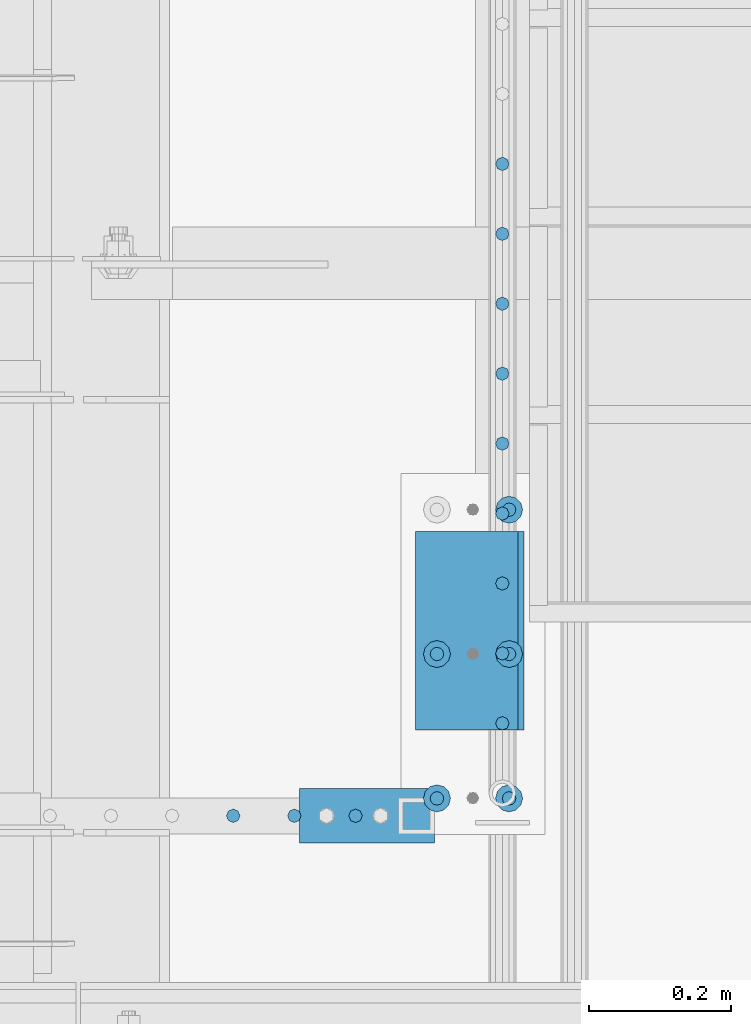
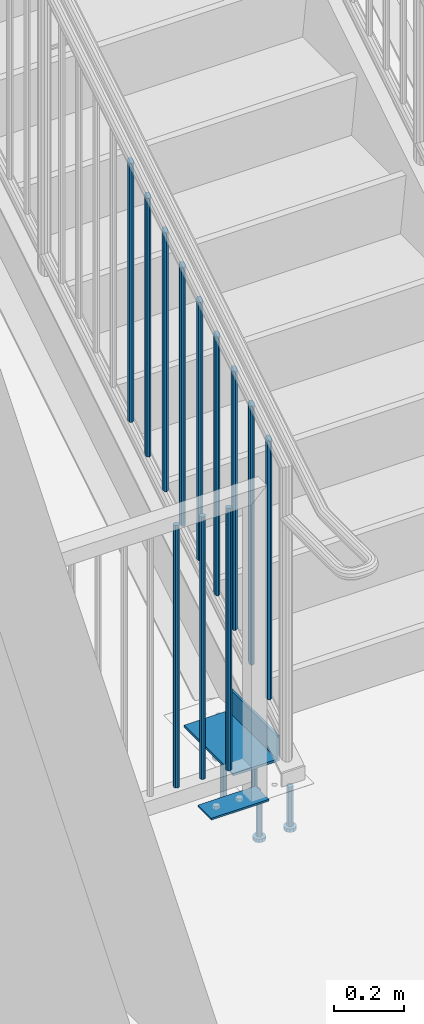
# One storey, part 1259 of 1763: 19 beams, 4 elements without a shape of their own.
"""IFC2X3 building model written with IfcOpenShell, lengths in millimetres."""

from ifc_helpers import new_model, si_unit, frame, origin_with_axes, place, context, subcontext, project, spatial, faceted_brep, material, type_object, element, aggregate, save


model = new_model("IFC2X3")

# Units and contexts
model_context = context("Model", 3, precision=1e-05, world=origin_with_axes())
body_context = subcontext(model_context, "Body", "Model", "MODEL_VIEW")
ifc_project = project(units=[si_unit("LENGTHUNIT", "METRE", prefix="MILLI"), si_unit("AREAUNIT", "SQUARE_METRE"), si_unit("VOLUMEUNIT", "CUBIC_METRE"), si_unit("MASSUNIT", "GRAM", prefix="KILO"), si_unit("TIMEUNIT", "SECOND"), si_unit("PLANEANGLEUNIT", "RADIAN"), si_unit("SOLIDANGLEUNIT", "STERADIAN"), si_unit("THERMODYNAMICTEMPERATUREUNIT", "DEGREE_CELSIUS"), si_unit("LUMINOUSINTENSITYUNIT", "LUMEN")], contexts=[model_context])

# Site, building, storey
site_placement = place(None, origin_with_axes())
site = spatial("IfcSite", under=ifc_project, at=site_placement, CompositionType="ELEMENT")
building_placement = place(site_placement, origin_with_axes())
building = spatial("IfcBuilding", under=site, at=building_placement, Name="Undefined", CompositionType="ELEMENT")
storey_placement = place(building_placement, origin_with_axes())
storey = spatial("IfcBuildingStorey", under=building, at=storey_placement, Name="Undefined", CompositionType="ELEMENT", Elevation=0.0)

# Assembly, beams
assembly_1_placement = place(storey_placement, origin_with_axes())
assembly_1 = element("IfcElementAssembly", 1, at=assembly_1_placement, inside=storey, Name="GUARDRAIL", AssemblyPlace="NOTDEFINED", PredefinedType="RIGID_FRAME")
ifc_material_1 = material(Name="STEEL/A36")
beam_type_1 = type_object("IfcBeamType", PredefinedType="NOTDEFINED")
beam_1_placement = place(assembly_1_placement, frame((-86969.0372737229, 31984.9500064728, 307.975030132566), z_axis=(-1.0, 0.0, 0.0), x_axis=(0.0, 1.0, 0.0)))
beam_1 = element("IfcBeam", 2, at=beam_1_placement, type_object=beam_type_1, material=ifc_material_1, context=body_context, shape_type="Brep", body=[
    faceted_brep([(0.0, 3.17500000000001, -95.25), (0.0, 3.17499999999927, 95.25), (76.1999968561649, 3.17499999984284, 95.25), (76.1999999999971, 3.17500000000001, -95.25), (0.0, -3.17499999999927, 95.25), (76.1999970403122, -3.17500000015571, 95.25), (0.0, -3.17500000000001, -95.25), (76.1999999999971, -3.17500000000001, -95.25)], [[[0, 1, 2, 3]], [[1, 4, 5, 2]], [[4, 6, 7, 5]], [[6, 0, 3, 7]], [[5, 7, 3, 2]], [[6, 4, 1, 0]]]),
])
beam_type_2 = type_object("IfcBeamType", PredefinedType="NOTDEFINED")
beam_2_placement = place(assembly_1_placement, frame((-86985.2650514979, 32023.0500064728, 1346.20003013257), z_axis=(1.0, 0.0, 0.0), x_axis=(0.0, 0.0, -1.0)))
beam_2 = element("IfcBeam", 3, at=beam_2_placement, type_object=beam_type_2, material=ifc_material_1, Name="PICKET", context=body_context, shape_type="Brep", body=[
    faceted_brep([(0.0, -9.52500000000146, 0.0), (0.0, -6.73519209080041, -6.73519209079677), (913.809358181841, -6.73519209080041, -6.73519209079677), (913.809358181841, -9.52500000000146, 0.0), (0.0, 0.0, -9.52499999999418), (913.809358181841, 0.0, -9.52499999999418), (0.0, 6.73519209080041, -6.73519209079677), (913.809358181841, 6.73519209080041, -6.73519209079677), (0.0, 9.52500000000146, 0.0), (913.809358181841, 9.52500000000146, 0.0), (0.0, 6.73519209080041, 6.73519209079677), (913.809358181841, 6.73519209080041, 6.73519209079677), (0.0, 0.0, 9.52499999999418), (913.809358181841, 0.0, 9.52499999999418), (0.0, -6.73519209080041, 6.73519209079677), (913.809358181841, -6.73519209080041, 6.73519209079677)], [[[0, 1, 2, 3]], [[1, 4, 5, 2]], [[4, 6, 7, 5]], [[6, 8, 9, 7]], [[8, 10, 11, 9]], [[10, 12, 13, 11]], [[12, 14, 15, 13]], [[14, 0, 3, 15]], [[5, 7, 9, 11, 13, 15, 3, 2]], [[14, 12, 10, 8, 6, 4, 1, 0]]]),
])
beam_3_placement = place(assembly_1_placement, frame((-87071.342829273, 32023.0500064728, 1346.20003013257), z_axis=(1.0, 0.0, 0.0), x_axis=(0.0, 0.0, -1.0)))
beam_3 = element("IfcBeam", 4, at=beam_3_placement, type_object=beam_type_2, material=ifc_material_1, Name="PICKET", context=body_context, shape_type="Brep", body=[
    faceted_brep([(0.0, -9.52500000000146, 0.0), (0.0, -6.73519209080041, -6.73519209079677), (913.809358181841, -6.73519209080041, -6.73519209079677), (913.809358181841, -9.52500000000146, 0.0), (0.0, 0.0, -9.52499999999418), (913.809358181841, 0.0, -9.52499999999418), (0.0, 6.73519209080041, -6.73519209079677), (913.809358181841, 6.73519209080041, -6.73519209079677), (0.0, 9.52500000000146, 0.0), (913.809358181841, 9.52500000000146, 0.0), (0.0, 6.73519209080041, 6.73519209079677), (913.809358181841, 6.73519209080041, 6.73519209079677), (0.0, 0.0, 9.52499999999418), (913.809358181841, 0.0, 9.52499999999418), (0.0, -6.73519209080041, 6.73519209079677), (913.809358181841, -6.73519209080041, 6.73519209079677)], [[[0, 1, 2, 3]], [[1, 4, 5, 2]], [[4, 6, 7, 5]], [[6, 8, 9, 7]], [[8, 10, 11, 9]], [[10, 12, 13, 11]], [[12, 14, 15, 13]], [[14, 0, 3, 15]], [[5, 7, 9, 11, 13, 15, 3, 2]], [[14, 12, 10, 8, 6, 4, 1, 0]]]),
])
beam_4_placement = place(assembly_1_placement, frame((-87157.420607048, 32023.0500064728, 1346.20003013257), z_axis=(1.0, 0.0, 0.0), x_axis=(0.0, 0.0, -1.0)))
beam_4 = element("IfcBeam", 5, at=beam_4_placement, type_object=beam_type_2, material=ifc_material_1, Name="PICKET", context=body_context, shape_type="Brep", body=[
    faceted_brep([(0.0, -9.52500000000146, 0.0), (0.0, -6.73519209080041, -6.73519209079677), (913.809358181841, -6.73519209080041, -6.73519209079677), (913.809358181841, -9.52500000000146, 0.0), (0.0, 0.0, -9.52499999999418), (913.809358181841, 0.0, -9.52499999999418), (0.0, 6.73519209080041, -6.73519209079677), (913.809358181841, 6.73519209080041, -6.73519209079677), (0.0, 9.52500000000146, 0.0), (913.809358181841, 9.52500000000146, 0.0), (0.0, 6.73519209080041, 6.73519209079677), (913.809358181841, 6.73519209080041, 6.73519209079677), (0.0, 0.0, 9.52499999999418), (913.809358181841, 0.0, 9.52499999999418), (0.0, -6.73519209080041, 6.73519209079677), (913.809358181841, -6.73519209080041, 6.73519209079677)], [[[0, 1, 2, 3]], [[1, 4, 5, 2]], [[4, 6, 7, 5]], [[6, 8, 9, 7]], [[8, 10, 11, 9]], [[10, 12, 13, 11]], [[12, 14, 15, 13]], [[14, 0, 3, 15]], [[5, 7, 9, 11, 13, 15, 3, 2]], [[14, 12, 10, 8, 6, 4, 1, 0]]]),
])
aggregate(assembly_1, [beam_1, beam_2, beam_3, beam_4])

assembly_2_placement = place(storey_placement, origin_with_axes())
assembly_2 = element("IfcElementAssembly", 6, at=assembly_2_placement, inside=storey, Name="RAIL", AssemblyPlace="NOTDEFINED", PredefinedType="RIGID_FRAME")
beam_5_placement = place(assembly_2_placement, frame((-86778.5372736927, 32940.8971432264, 1945.09755526752), z_axis=(-1.0, 0.0, 0.0), x_axis=(0.0, 0.0, -1.0)))
beam_5 = element("IfcBeam", 7, at=beam_5_placement, type_object=beam_type_2, material=ifc_material_1, Name="PICKET", context=body_context, shape_type="Brep", body=[
    faceted_brep([(16.5091072770651, -9.52500000000146, 0.0), (18.2402825153672, -6.73519209080405, -6.73519209079677), (919.550864034841, -6.73519209080405, -6.73519209079677), (917.819688796539, -9.52500000000146, 0.0), (22.4197092545201, 0.0, -9.52499999999418), (923.730290773995, 0.0, -9.52499999999418), (26.5991359936734, 6.73519209080405, -6.73519209079677), (927.909717513148, 6.73519209080405, -6.73519209079677), (28.330311231975, 9.52500000000146, 0.0), (929.64089275145, 9.52500000000146, 0.0), (26.5991359936734, 6.73519209080405, 6.73519209079677), (927.909717513148, 6.73519209080405, 6.73519209079677), (22.4197092545201, 0.0, 9.52499999999418), (923.730290773995, 0.0, 9.52499999999418), (18.2402825153672, -6.73519209080405, 6.73519209079677), (919.550864034841, -6.73519209080405, 6.73519209079677)], [[[0, 1, 2, 3]], [[1, 4, 5, 2]], [[4, 6, 7, 5]], [[6, 8, 9, 7]], [[8, 10, 11, 9]], [[10, 12, 13, 11]], [[12, 14, 15, 13]], [[14, 0, 3, 15]], [[13, 15, 3, 2, 5, 7, 9, 11]], [[14, 12, 10, 8, 6, 4, 1, 0]]]),
])
beam_6_placement = place(assembly_2_placement, frame((-86778.5372736927, 32842.4419051312, 1884.00257101841), z_axis=(-1.0, 0.0, 0.0), x_axis=(0.0, 0.0, -1.0)))
beam_6 = element("IfcBeam", 8, at=beam_6_placement, type_object=beam_type_2, material=ifc_material_1, Name="PICKET", context=body_context, shape_type="Brep", body=[
    faceted_brep([(16.5091072770651, -9.52500000000146, 0.0), (18.2402825153672, -6.73519209080405, -6.73519209079677), (919.550864034841, -6.73519209080405, -6.73519209079677), (917.819688796539, -9.52500000000146, 0.0), (22.4197092545201, 0.0, -9.52499999999418), (923.730290773995, 0.0, -9.52499999999418), (26.5991359936734, 6.73519209080405, -6.73519209079677), (927.909717513148, 6.73519209080405, -6.73519209079677), (28.330311231975, 9.52500000000146, 0.0), (929.64089275145, 9.52500000000146, 0.0), (26.5991359936734, 6.73519209080405, 6.73519209079677), (927.909717513148, 6.73519209080405, 6.73519209079677), (22.4197092545201, 0.0, 9.52499999999418), (923.730290773995, 0.0, 9.52499999999418), (18.2402825153672, -6.73519209080405, 6.73519209079677), (919.550864034841, -6.73519209080405, 6.73519209079677)], [[[0, 1, 2, 3]], [[1, 4, 5, 2]], [[4, 6, 7, 5]], [[6, 8, 9, 7]], [[8, 10, 11, 9]], [[10, 12, 13, 11]], [[12, 14, 15, 13]], [[14, 0, 3, 15]], [[13, 15, 3, 2, 5, 7, 9, 11]], [[14, 12, 10, 8, 6, 4, 1, 0]]]),
])
beam_7_placement = place(assembly_2_placement, frame((-86778.5372736927, 32743.986667036, 1822.90758676929), z_axis=(-1.0, 0.0, 0.0), x_axis=(0.0, 0.0, -1.0)))
beam_7 = element("IfcBeam", 9, at=beam_7_placement, type_object=beam_type_2, material=ifc_material_1, Name="PICKET", context=body_context, shape_type="Brep", body=[
    faceted_brep([(16.5091072770651, -9.52500000000146, 0.0), (18.2402825153672, -6.73519209080405, -6.73519209079677), (919.550864034841, -6.73519209080405, -6.73519209079677), (917.819688796539, -9.52500000000146, 0.0), (22.4197092545201, 0.0, -9.52499999999418), (923.730290773995, 0.0, -9.52499999999418), (26.5991359936734, 6.73519209080405, -6.73519209079677), (927.909717513148, 6.73519209080405, -6.73519209079677), (28.330311231975, 9.52500000000146, 0.0), (929.64089275145, 9.52500000000146, 0.0), (26.5991359936734, 6.73519209080405, 6.73519209079677), (927.909717513148, 6.73519209080405, 6.73519209079677), (22.4197092545201, 0.0, 9.52499999999418), (923.730290773995, 0.0, 9.52499999999418), (18.2402825153672, -6.73519209080405, 6.73519209079677), (919.550864034841, -6.73519209080405, 6.73519209079677)], [[[0, 1, 2, 3]], [[1, 4, 5, 2]], [[4, 6, 7, 5]], [[6, 8, 9, 7]], [[8, 10, 11, 9]], [[10, 12, 13, 11]], [[12, 14, 15, 13]], [[14, 0, 3, 15]], [[13, 15, 3, 2, 5, 7, 9, 11]], [[14, 12, 10, 8, 6, 4, 1, 0]]]),
])
beam_8_placement = place(assembly_2_placement, frame((-86778.5372736927, 32645.5314289407, 1761.81260252017), z_axis=(-1.0, 0.0, 0.0), x_axis=(0.0, 0.0, -1.0)))
beam_8 = element("IfcBeam", 10, at=beam_8_placement, type_object=beam_type_2, material=ifc_material_1, Name="PICKET", context=body_context, shape_type="Brep", body=[
    faceted_brep([(16.5091072770651, -9.52500000000146, 0.0), (18.2402825153672, -6.73519209080405, -6.73519209079677), (919.550864034841, -6.73519209080405, -6.73519209079677), (917.819688796539, -9.52500000000146, 0.0), (22.4197092545201, 0.0, -9.52499999999418), (923.730290773995, 0.0, -9.52499999999418), (26.5991359936734, 6.73519209080405, -6.73519209079677), (927.909717513148, 6.73519209080405, -6.73519209079677), (28.330311231975, 9.52500000000146, 0.0), (929.64089275145, 9.52500000000146, 0.0), (26.5991359936734, 6.73519209080405, 6.73519209079677), (927.909717513148, 6.73519209080405, 6.73519209079677), (22.4197092545201, 0.0, 9.52499999999418), (923.730290773995, 0.0, 9.52499999999418), (18.2402825153672, -6.73519209080405, 6.73519209079677), (919.550864034841, -6.73519209080405, 6.73519209079677)], [[[0, 1, 2, 3]], [[1, 4, 5, 2]], [[4, 6, 7, 5]], [[6, 8, 9, 7]], [[8, 10, 11, 9]], [[10, 12, 13, 11]], [[12, 14, 15, 13]], [[14, 0, 3, 15]], [[13, 15, 3, 2, 5, 7, 9, 11]], [[14, 12, 10, 8, 6, 4, 1, 0]]]),
])
beam_9_placement = place(assembly_2_placement, frame((-86778.5372736927, 32547.0761908455, 1700.71761827105), z_axis=(-1.0, 0.0, 0.0), x_axis=(0.0, 0.0, -1.0)))
beam_9 = element("IfcBeam", 11, at=beam_9_placement, type_object=beam_type_2, material=ifc_material_1, Name="PICKET", context=body_context, shape_type="Brep", body=[
    faceted_brep([(16.5091072770651, -9.52500000000146, 0.0), (18.2402825153672, -6.73519209080405, -6.73519209079677), (919.550864034841, -6.73519209080405, -6.73519209079677), (917.819688796539, -9.52500000000146, 0.0), (22.4197092545201, 0.0, -9.52499999999418), (923.730290773995, 0.0, -9.52499999999418), (26.5991359936734, 6.73519209080405, -6.73519209079677), (927.909717513148, 6.73519209080405, -6.73519209079677), (28.330311231975, 9.52500000000146, 0.0), (929.64089275145, 9.52500000000146, 0.0), (26.5991359936734, 6.73519209080405, 6.73519209079677), (927.909717513148, 6.73519209080405, 6.73519209079677), (22.4197092545201, 0.0, 9.52499999999418), (923.730290773995, 0.0, 9.52499999999418), (18.2402825153672, -6.73519209080405, 6.73519209079677), (919.550864034841, -6.73519209080405, 6.73519209079677)], [[[0, 1, 2, 3]], [[1, 4, 5, 2]], [[4, 6, 7, 5]], [[6, 8, 9, 7]], [[8, 10, 11, 9]], [[10, 12, 13, 11]], [[12, 14, 15, 13]], [[14, 0, 3, 15]], [[13, 15, 3, 2, 5, 7, 9, 11]], [[14, 12, 10, 8, 6, 4, 1, 0]]]),
])
beam_10_placement = place(assembly_2_placement, frame((-86778.5372736927, 32448.6209527502, 1639.62263402193), z_axis=(-1.0, 0.0, 0.0), x_axis=(0.0, 0.0, -1.0)))
beam_10 = element("IfcBeam", 12, at=beam_10_placement, type_object=beam_type_2, material=ifc_material_1, Name="PICKET", context=body_context, shape_type="Brep", body=[
    faceted_brep([(16.5091072770651, -9.52500000000146, 0.0), (18.2402825153672, -6.73519209080405, -6.73519209079677), (919.550864034841, -6.73519209080405, -6.73519209079677), (917.819688796539, -9.52500000000146, 0.0), (22.4197092545201, 0.0, -9.52499999999418), (923.730290773995, 0.0, -9.52499999999418), (26.5991359936734, 6.73519209080405, -6.73519209079677), (927.909717513148, 6.73519209080405, -6.73519209079677), (28.330311231975, 9.52500000000146, 0.0), (929.64089275145, 9.52500000000146, 0.0), (26.5991359936734, 6.73519209080405, 6.73519209079677), (927.909717513148, 6.73519209080405, 6.73519209079677), (22.4197092545201, 0.0, 9.52499999999418), (923.730290773995, 0.0, 9.52499999999418), (18.2402825153672, -6.73519209080405, 6.73519209079677), (919.550864034841, -6.73519209080405, 6.73519209079677)], [[[0, 1, 2, 3]], [[1, 4, 5, 2]], [[4, 6, 7, 5]], [[6, 8, 9, 7]], [[8, 10, 11, 9]], [[10, 12, 13, 11]], [[12, 14, 15, 13]], [[14, 0, 3, 15]], [[13, 15, 3, 2, 5, 7, 9, 11]], [[14, 12, 10, 8, 6, 4, 1, 0]]]),
])
beam_11_placement = place(assembly_2_placement, frame((-86778.5372736927, 32350.165714655, 1578.52764977282), z_axis=(-1.0, 0.0, 0.0), x_axis=(0.0, 0.0, -1.0)))
beam_11 = element("IfcBeam", 13, at=beam_11_placement, type_object=beam_type_2, material=ifc_material_1, Name="PICKET", context=body_context, shape_type="Brep", body=[
    faceted_brep([(16.5091072770651, -9.52500000000146, 0.0), (18.2402825153672, -6.73519209080405, -6.73519209079677), (919.550864034841, -6.73519209080405, -6.73519209079677), (917.819688796539, -9.52500000000146, 0.0), (22.4197092545201, 0.0, -9.52499999999418), (923.730290773995, 0.0, -9.52499999999418), (26.5991359936734, 6.73519209080405, -6.73519209079677), (927.909717513148, 6.73519209080405, -6.73519209079677), (28.330311231975, 9.52500000000146, 0.0), (929.64089275145, 9.52500000000146, 0.0), (26.5991359936734, 6.73519209080405, 6.73519209079677), (927.909717513148, 6.73519209080405, 6.73519209079677), (22.4197092545201, 0.0, 9.52499999999418), (923.730290773995, 0.0, 9.52499999999418), (18.2402825153672, -6.73519209080405, 6.73519209079677), (919.550864034841, -6.73519209080405, 6.73519209079677)], [[[0, 1, 2, 3]], [[1, 4, 5, 2]], [[4, 6, 7, 5]], [[6, 8, 9, 7]], [[8, 10, 11, 9]], [[10, 12, 13, 11]], [[12, 14, 15, 13]], [[14, 0, 3, 15]], [[13, 15, 3, 2, 5, 7, 9, 11]], [[14, 12, 10, 8, 6, 4, 1, 0]]]),
])
beam_12_placement = place(assembly_2_placement, frame((-86778.5372736927, 32251.7104765598, 1517.4326655237), z_axis=(-1.0, 0.0, 0.0), x_axis=(0.0, 0.0, -1.0)))
beam_12 = element("IfcBeam", 14, at=beam_12_placement, type_object=beam_type_2, material=ifc_material_1, Name="PICKET", context=body_context, shape_type="Brep", body=[
    faceted_brep([(16.5091072770651, -9.52500000000146, 0.0), (18.2402825153672, -6.73519209080405, -6.73519209079677), (919.550864034841, -6.73519209080405, -6.73519209079677), (917.819688796539, -9.52500000000146, 0.0), (22.4197092545201, 0.0, -9.52499999999418), (923.730290773995, 0.0, -9.52499999999418), (26.5991359936734, 6.73519209080405, -6.73519209079677), (927.909717513148, 6.73519209080405, -6.73519209079677), (28.330311231975, 9.52500000000146, 0.0), (929.64089275145, 9.52500000000146, 0.0), (26.5991359936734, 6.73519209080405, 6.73519209079677), (927.909717513148, 6.73519209080405, 6.73519209079677), (22.4197092545201, 0.0, 9.52499999999418), (923.730290773995, 0.0, 9.52499999999418), (18.2402825153672, -6.73519209080405, 6.73519209079677), (919.550864034841, -6.73519209080405, 6.73519209079677)], [[[0, 1, 2, 3]], [[1, 4, 5, 2]], [[4, 6, 7, 5]], [[6, 8, 9, 7]], [[8, 10, 11, 9]], [[10, 12, 13, 11]], [[12, 14, 15, 13]], [[14, 0, 3, 15]], [[13, 15, 3, 2, 5, 7, 9, 11]], [[14, 12, 10, 8, 6, 4, 1, 0]]]),
])
beam_13_placement = place(assembly_2_placement, frame((-86778.5372736927, 32153.2552384645, 1456.33768127458), z_axis=(-1.0, 0.0, 0.0), x_axis=(0.0, 0.0, -1.0)))
beam_13 = element("IfcBeam", 15, at=beam_13_placement, type_object=beam_type_2, material=ifc_material_1, Name="PICKET", context=body_context, shape_type="Brep", body=[
    faceted_brep([(16.5091072770651, -9.52500000000146, 0.0), (18.2402825153672, -6.73519209080405, -6.73519209079677), (919.550864034841, -6.73519209080405, -6.73519209079677), (917.819688796539, -9.52500000000146, 0.0), (22.4197092545201, 0.0, -9.52499999999418), (923.730290773995, 0.0, -9.52499999999418), (26.5991359936734, 6.73519209080405, -6.73519209079677), (927.909717513148, 6.73519209080405, -6.73519209079677), (28.330311231975, 9.52500000000146, 0.0), (929.64089275145, 9.52500000000146, 0.0), (26.5991359936734, 6.73519209080405, 6.73519209079677), (927.909717513148, 6.73519209080405, 6.73519209079677), (22.4197092545201, 0.0, 9.52499999999418), (923.730290773995, 0.0, 9.52499999999418), (18.2402825153672, -6.73519209080405, 6.73519209079677), (919.550864034841, -6.73519209080405, 6.73519209079677)], [[[0, 1, 2, 3]], [[1, 4, 5, 2]], [[4, 6, 7, 5]], [[6, 8, 9, 7]], [[8, 10, 11, 9]], [[10, 12, 13, 11]], [[12, 14, 15, 13]], [[14, 0, 3, 15]], [[13, 15, 3, 2, 5, 7, 9, 11]], [[14, 12, 10, 8, 6, 4, 1, 0]]]),
])
aggregate(assembly_2, [beam_5, beam_6, beam_7, beam_8, beam_9, beam_10, beam_11, beam_12, beam_13])

# Assembly, beam
assembly_3_placement = place(storey_placement, origin_with_axes())
assembly_3 = element("IfcElementAssembly", 16, at=assembly_3_placement, inside=storey, Name="STRINGER", AssemblyPlace="NOTDEFINED", PredefinedType="RIGID_FRAME")
beam_type_3 = type_object("IfcBeamType", Name="L6X3-1/2X5/16", PredefinedType="NOTDEFINED")
beam_14_placement = place(assembly_3_placement, frame((-86824.5747737229, 32143.7000003621, 349.249782502056), z_axis=(-1.0, 0.0, 0.0), x_axis=(0.0, 1.0, 0.0)))
beam_14 = element("IfcBeam", 17, at=beam_14_placement, type_object=beam_type_3, material=ifc_material_1, Name="ANGLE", ObjectType="L6X3-1/2X5/16", context=body_context, shape_type="Brep", body=[
    faceted_brep([(0.0, 44.45, -76.1999999999971), (0.0, 44.45, 76.1999999999971), (279.400000000001, 44.45, 76.1999999999971), (279.400000000001, 44.45, -76.1999999999971), (0.0, 36.5125, 76.1999999999971), (279.400000000001, 36.5125, 76.1999999999971), (0.0, 36.5125, -68.2624999999971), (279.400000000001, 36.5125, -68.2624999999971), (0.0, -44.45, -68.2624999999971), (279.400000000001, -44.45, -68.2624999999971), (0.0, -44.45, -76.1999999999971), (279.400000000001, -44.45, -76.1999999999971)], [[[0, 1, 2, 3]], [[1, 4, 5, 2]], [[4, 6, 7, 5]], [[6, 8, 9, 7]], [[8, 10, 11, 9]], [[10, 0, 3, 11]], [[5, 7, 9, 11, 3, 2]], [[10, 8, 6, 4, 1, 0]]]),
])
aggregate(assembly_3, [beam_14])

# Assembly, beams
assembly_4_placement = place(storey_placement, origin_with_axes())
assembly_4 = element("IfcElementAssembly", 18, at=assembly_4_placement, inside=storey, Name="PLATE", AssemblyPlace="NOTDEFINED", PredefinedType="RIGID_FRAME")
ifc_material_2 = material(Name="STEEL/A108")
beam_type_4 = type_object("IfcBeamType", Name="STUD_3/4-DIA", PredefinedType="NOTDEFINED")
beam_15_placement = place(assembly_4_placement, frame((-86769.0122706704, 32047.5777095314, 285.750030132579), z_axis=(1.0, 0.0, 0.0), x_axis=(0.0, 0.0, -1.0)))
beam_15 = element("IfcBeam", 19, at=beam_15_placement, type_object=beam_type_4, material=ifc_material_2, Name="BEAM", ObjectType="STUD_3/4-DIA", context=body_context, shape_type="Brep", body=[
    faceted_brep([(0.0, -9.52000045776367, 0.0), (0.0, -8.25, -4.76000022888184), (138.684, -8.25, -4.76000022888184), (138.684, -9.52000045776367, 0.0), (0.0, -4.76000022888184, -8.25), (138.684, -4.76000022888184, -8.25), (0.0, 0.0, -9.52000045776367), (138.684, 0.0, -9.52000045776367), (0.0, 4.76000022888184, -8.25), (138.684, 4.76000022888184, -8.25), (0.0, 8.25, -4.76000022888184), (138.684, 8.25, -4.76000022888184), (0.0, 9.52000045776367, 0.0), (138.684, 9.52000045776367, 0.0), (0.0, 8.25, 4.76000022888184), (138.684, 8.25, 4.76000022888184), (0.0, 4.76000022888184, 8.25), (138.684, 4.76000022888184, 8.25), (0.0, 0.0, 9.52000045776367), (138.684, 0.0, 9.52000045776367), (0.0, -4.76000022888184, 8.25), (138.684, -4.76000022888184, 8.25), (0.0, -8.25, 4.76000022888184), (138.684, -8.25, 4.76000022888184), (140.208, -16.5, -9.52000045776367), (140.208, -19.0499992370605, 0.0), (140.208, -9.52000045776367, -16.5), (140.208, 0.0, -19.0499992370605), (140.208, 9.52000045776367, -16.5), (140.208, 16.5, -9.52000045776367), (140.208, 19.0499992370605, 0.0), (140.208, 16.5, 9.52000045776367), (140.208, 9.52000045776367, 16.5), (140.208, 0.0, 19.0499992370605), (140.208, -9.52000045776367, 16.5), (140.208, -16.5, 9.52000045776367), (152.4, -16.5, -9.52000045776367), (152.4, -19.0499992370605, 0.0), (152.4, -9.52000045776367, -16.5), (152.4, 0.0, -19.0499992370605), (152.4, 9.52000045776367, -16.5), (152.4, 16.5, -9.52000045776367), (152.4, 19.0499992370605, 0.0), (152.4, 16.5, 9.52000045776367), (152.4, 9.52000045776367, 16.5), (152.4, 0.0, 19.0499992370605), (152.4, -9.52000045776367, 16.5), (152.4, -16.5, 9.52000045776367)], [[[0, 1, 2, 3]], [[1, 4, 5, 2]], [[4, 6, 7, 5]], [[6, 8, 9, 7]], [[8, 10, 11, 9]], [[10, 12, 13, 11]], [[12, 14, 15, 13]], [[14, 16, 17, 15]], [[16, 18, 19, 17]], [[18, 20, 21, 19]], [[20, 22, 23, 21]], [[22, 0, 3, 23]], [[22, 20, 18, 16, 14, 12, 10, 8, 6, 4, 1, 0]], [[3, 2, 24, 25]], [[2, 5, 26, 24]], [[5, 7, 27, 26]], [[7, 9, 28, 27]], [[9, 11, 29, 28]], [[11, 13, 30, 29]], [[13, 15, 31, 30]], [[15, 17, 32, 31]], [[17, 19, 33, 32]], [[19, 21, 34, 33]], [[21, 23, 35, 34]], [[23, 3, 25, 35]], [[25, 24, 36, 37]], [[24, 26, 38, 36]], [[26, 27, 39, 38]], [[27, 28, 40, 39]], [[28, 29, 41, 40]], [[29, 30, 42, 41]], [[30, 31, 43, 42]], [[31, 32, 44, 43]], [[32, 33, 45, 44]], [[33, 34, 46, 45]], [[34, 35, 47, 46]], [[35, 25, 37, 47]], [[38, 39, 40, 41, 42, 43, 44, 45, 46, 47, 37, 36]]]),
])
beam_16_placement = place(assembly_4_placement, frame((-86870.6122706704, 32047.5777095314, 285.75003013257), z_axis=(1.0, 0.0, 0.0), x_axis=(0.0, 0.0, -1.0)))
beam_16 = element("IfcBeam", 20, at=beam_16_placement, type_object=beam_type_4, material=ifc_material_2, Name="BEAM", ObjectType="STUD_3/4-DIA", context=body_context, shape_type="Brep", body=[
    faceted_brep([(0.0, -9.52000045776367, 0.0), (0.0, -8.25, -4.76000022888184), (138.684, -8.25, -4.76000022888184), (138.684, -9.52000045776367, 0.0), (0.0, -4.76000022888184, -8.25), (138.684, -4.76000022888184, -8.25), (0.0, 0.0, -9.52000045776367), (138.684, 0.0, -9.52000045776367), (0.0, 4.76000022888184, -8.25), (138.684, 4.76000022888184, -8.25), (0.0, 8.25, -4.76000022888184), (138.684, 8.25, -4.76000022888184), (0.0, 9.52000045776367, 0.0), (138.684, 9.52000045776367, 0.0), (0.0, 8.25, 4.76000022888184), (138.684, 8.25, 4.76000022888184), (0.0, 4.76000022888184, 8.25), (138.684, 4.76000022888184, 8.25), (0.0, 0.0, 9.52000045776367), (138.684, 0.0, 9.52000045776367), (0.0, -4.76000022888184, 8.25), (138.684, -4.76000022888184, 8.25), (0.0, -8.25, 4.76000022888184), (138.684, -8.25, 4.76000022888184), (140.208, -16.5, -9.52000045776367), (140.208, -19.0499992370605, 0.0), (140.208, -9.52000045776367, -16.5), (140.208, 0.0, -19.0499992370605), (140.208, 9.52000045776367, -16.5), (140.208, 16.5, -9.52000045776367), (140.208, 19.0499992370605, 0.0), (140.208, 16.5, 9.52000045776367), (140.208, 9.52000045776367, 16.5), (140.208, 0.0, 19.0499992370605), (140.208, -9.52000045776367, 16.5), (140.208, -16.5, 9.52000045776367), (152.4, -16.5, -9.52000045776367), (152.4, -19.0499992370605, 0.0), (152.4, -9.52000045776367, -16.5), (152.4, 0.0, -19.0499992370605), (152.4, 9.52000045776367, -16.5), (152.4, 16.5, -9.52000045776367), (152.4, 19.0499992370605, 0.0), (152.4, 16.5, 9.52000045776367), (152.4, 9.52000045776367, 16.5), (152.4, 0.0, 19.0499992370605), (152.4, -9.52000045776367, 16.5), (152.4, -16.5, 9.52000045776367)], [[[0, 1, 2, 3]], [[1, 4, 5, 2]], [[4, 6, 7, 5]], [[6, 8, 9, 7]], [[8, 10, 11, 9]], [[10, 12, 13, 11]], [[12, 14, 15, 13]], [[14, 16, 17, 15]], [[16, 18, 19, 17]], [[18, 20, 21, 19]], [[20, 22, 23, 21]], [[22, 0, 3, 23]], [[22, 20, 18, 16, 14, 12, 10, 8, 6, 4, 1, 0]], [[3, 2, 24, 25]], [[2, 5, 26, 24]], [[5, 7, 27, 26]], [[7, 9, 28, 27]], [[9, 11, 29, 28]], [[11, 13, 30, 29]], [[13, 15, 31, 30]], [[15, 17, 32, 31]], [[17, 19, 33, 32]], [[19, 21, 34, 33]], [[21, 23, 35, 34]], [[23, 3, 25, 35]], [[25, 24, 36, 37]], [[24, 26, 38, 36]], [[26, 27, 39, 38]], [[27, 28, 40, 39]], [[28, 29, 41, 40]], [[29, 30, 42, 41]], [[30, 31, 43, 42]], [[31, 32, 44, 43]], [[32, 33, 45, 44]], [[33, 34, 46, 45]], [[34, 35, 47, 46]], [[35, 25, 37, 47]], [[38, 39, 40, 41, 42, 43, 44, 45, 46, 47, 37, 36]]]),
])
beam_17_placement = place(assembly_4_placement, frame((-86769.0122706704, 32250.7777095314, 285.75003013257), z_axis=(1.0, 0.0, 0.0), x_axis=(0.0, 0.0, -1.0)))
beam_17 = element("IfcBeam", 21, at=beam_17_placement, type_object=beam_type_4, material=ifc_material_2, Name="BEAM", ObjectType="STUD_3/4-DIA", context=body_context, shape_type="Brep", body=[
    faceted_brep([(0.0, -9.52000045776367, 0.0), (0.0, -8.25, -4.76000022888184), (138.684, -8.25, -4.76000022888184), (138.684, -9.52000045776367, 0.0), (0.0, -4.76000022888184, -8.25), (138.684, -4.76000022888184, -8.25), (0.0, 0.0, -9.52000045776367), (138.684, 0.0, -9.52000045776367), (0.0, 4.76000022888184, -8.25), (138.684, 4.76000022888184, -8.25), (0.0, 8.25, -4.76000022888184), (138.684, 8.25, -4.76000022888184), (0.0, 9.52000045776367, 0.0), (138.684, 9.52000045776367, 0.0), (0.0, 8.25, 4.76000022888184), (138.684, 8.25, 4.76000022888184), (0.0, 4.76000022888184, 8.25), (138.684, 4.76000022888184, 8.25), (0.0, 0.0, 9.52000045776367), (138.684, 0.0, 9.52000045776367), (0.0, -4.76000022888184, 8.25), (138.684, -4.76000022888184, 8.25), (0.0, -8.25, 4.76000022888184), (138.684, -8.25, 4.76000022888184), (140.208, -16.5, -9.52000045776367), (140.208, -19.0499992370605, 0.0), (140.208, -9.52000045776367, -16.5), (140.208, 0.0, -19.0499992370605), (140.208, 9.52000045776367, -16.5), (140.208, 16.5, -9.52000045776367), (140.208, 19.0499992370605, 0.0), (140.208, 16.5, 9.52000045776367), (140.208, 9.52000045776367, 16.5), (140.208, 0.0, 19.0499992370605), (140.208, -9.52000045776367, 16.5), (140.208, -16.5, 9.52000045776367), (152.4, -16.5, -9.52000045776367), (152.4, -19.0499992370605, 0.0), (152.4, -9.52000045776367, -16.5), (152.4, 0.0, -19.0499992370605), (152.4, 9.52000045776367, -16.5), (152.4, 16.5, -9.52000045776367), (152.4, 19.0499992370605, 0.0), (152.4, 16.5, 9.52000045776367), (152.4, 9.52000045776367, 16.5), (152.4, 0.0, 19.0499992370605), (152.4, -9.52000045776367, 16.5), (152.4, -16.5, 9.52000045776367)], [[[0, 1, 2, 3]], [[1, 4, 5, 2]], [[4, 6, 7, 5]], [[6, 8, 9, 7]], [[8, 10, 11, 9]], [[10, 12, 13, 11]], [[12, 14, 15, 13]], [[14, 16, 17, 15]], [[16, 18, 19, 17]], [[18, 20, 21, 19]], [[20, 22, 23, 21]], [[22, 0, 3, 23]], [[22, 20, 18, 16, 14, 12, 10, 8, 6, 4, 1, 0]], [[3, 2, 24, 25]], [[2, 5, 26, 24]], [[5, 7, 27, 26]], [[7, 9, 28, 27]], [[9, 11, 29, 28]], [[11, 13, 30, 29]], [[13, 15, 31, 30]], [[15, 17, 32, 31]], [[17, 19, 33, 32]], [[19, 21, 34, 33]], [[21, 23, 35, 34]], [[23, 3, 25, 35]], [[25, 24, 36, 37]], [[24, 26, 38, 36]], [[26, 27, 39, 38]], [[27, 28, 40, 39]], [[28, 29, 41, 40]], [[29, 30, 42, 41]], [[30, 31, 43, 42]], [[31, 32, 44, 43]], [[32, 33, 45, 44]], [[33, 34, 46, 45]], [[34, 35, 47, 46]], [[35, 25, 37, 47]], [[38, 39, 40, 41, 42, 43, 44, 45, 46, 47, 37, 36]]]),
])
beam_18_placement = place(assembly_4_placement, frame((-86870.6122706704, 32250.7777095314, 285.750030132561), z_axis=(1.0, 0.0, 0.0), x_axis=(0.0, 0.0, -1.0)))
beam_18 = element("IfcBeam", 22, at=beam_18_placement, type_object=beam_type_4, material=ifc_material_2, Name="BEAM", ObjectType="STUD_3/4-DIA", context=body_context, shape_type="Brep", body=[
    faceted_brep([(0.0, -9.52000045776367, 0.0), (0.0, -8.25, -4.76000022888184), (138.684, -8.25, -4.76000022888184), (138.684, -9.52000045776367, 0.0), (0.0, -4.76000022888184, -8.25), (138.684, -4.76000022888184, -8.25), (0.0, 0.0, -9.52000045776367), (138.684, 0.0, -9.52000045776367), (0.0, 4.76000022888184, -8.25), (138.684, 4.76000022888184, -8.25), (0.0, 8.25, -4.76000022888184), (138.684, 8.25, -4.76000022888184), (0.0, 9.52000045776367, 0.0), (138.684, 9.52000045776367, 0.0), (0.0, 8.25, 4.76000022888184), (138.684, 8.25, 4.76000022888184), (0.0, 4.76000022888184, 8.25), (138.684, 4.76000022888184, 8.25), (0.0, 0.0, 9.52000045776367), (138.684, 0.0, 9.52000045776367), (0.0, -4.76000022888184, 8.25), (138.684, -4.76000022888184, 8.25), (0.0, -8.25, 4.76000022888184), (138.684, -8.25, 4.76000022888184), (140.208, -16.5, -9.52000045776367), (140.208, -19.0499992370605, 0.0), (140.208, -9.52000045776367, -16.5), (140.208, 0.0, -19.0499992370605), (140.208, 9.52000045776367, -16.5), (140.208, 16.5, -9.52000045776367), (140.208, 19.0499992370605, 0.0), (140.208, 16.5, 9.52000045776367), (140.208, 9.52000045776367, 16.5), (140.208, 0.0, 19.0499992370605), (140.208, -9.52000045776367, 16.5), (140.208, -16.5, 9.52000045776367), (152.4, -16.5, -9.52000045776367), (152.4, -19.0499992370605, 0.0), (152.4, -9.52000045776367, -16.5), (152.4, 0.0, -19.0499992370605), (152.4, 9.52000045776367, -16.5), (152.4, 16.5, -9.52000045776367), (152.4, 19.0499992370605, 0.0), (152.4, 16.5, 9.52000045776367), (152.4, 9.52000045776367, 16.5), (152.4, 0.0, 19.0499992370605), (152.4, -9.52000045776367, 16.5), (152.4, -16.5, 9.52000045776367)], [[[0, 1, 2, 3]], [[1, 4, 5, 2]], [[4, 6, 7, 5]], [[6, 8, 9, 7]], [[8, 10, 11, 9]], [[10, 12, 13, 11]], [[12, 14, 15, 13]], [[14, 16, 17, 15]], [[16, 18, 19, 17]], [[18, 20, 21, 19]], [[20, 22, 23, 21]], [[22, 0, 3, 23]], [[22, 20, 18, 16, 14, 12, 10, 8, 6, 4, 1, 0]], [[3, 2, 24, 25]], [[2, 5, 26, 24]], [[5, 7, 27, 26]], [[7, 9, 28, 27]], [[9, 11, 29, 28]], [[11, 13, 30, 29]], [[13, 15, 31, 30]], [[15, 17, 32, 31]], [[17, 19, 33, 32]], [[19, 21, 34, 33]], [[21, 23, 35, 34]], [[23, 3, 25, 35]], [[25, 24, 36, 37]], [[24, 26, 38, 36]], [[26, 27, 39, 38]], [[27, 28, 40, 39]], [[28, 29, 41, 40]], [[29, 30, 42, 41]], [[30, 31, 43, 42]], [[31, 32, 44, 43]], [[32, 33, 45, 44]], [[33, 34, 46, 45]], [[34, 35, 47, 46]], [[35, 25, 37, 47]], [[38, 39, 40, 41, 42, 43, 44, 45, 46, 47, 37, 36]]]),
])
beam_19_placement = place(assembly_4_placement, frame((-86769.0122706704, 32453.9777095314, 285.750030132565), z_axis=(1.0, 0.0, 0.0), x_axis=(0.0, 0.0, -1.0)))
beam_19 = element("IfcBeam", 23, at=beam_19_placement, type_object=beam_type_4, material=ifc_material_2, Name="BEAM", ObjectType="STUD_3/4-DIA", context=body_context, shape_type="Brep", body=[
    faceted_brep([(0.0, -9.52000045776367, 0.0), (0.0, -8.25, -4.76000022888184), (138.684, -8.25, -4.76000022888184), (138.684, -9.52000045776367, 0.0), (0.0, -4.76000022888184, -8.25), (138.684, -4.76000022888184, -8.25), (0.0, 0.0, -9.52000045776367), (138.684, 0.0, -9.52000045776367), (0.0, 4.76000022888184, -8.25), (138.684, 4.76000022888184, -8.25), (0.0, 8.25, -4.76000022888184), (138.684, 8.25, -4.76000022888184), (0.0, 9.52000045776367, 0.0), (138.684, 9.52000045776367, 0.0), (0.0, 8.25, 4.76000022888184), (138.684, 8.25, 4.76000022888184), (0.0, 4.76000022888184, 8.25), (138.684, 4.76000022888184, 8.25), (0.0, 0.0, 9.52000045776367), (138.684, 0.0, 9.52000045776367), (0.0, -4.76000022888184, 8.25), (138.684, -4.76000022888184, 8.25), (0.0, -8.25, 4.76000022888184), (138.684, -8.25, 4.76000022888184), (140.208, -16.5, -9.52000045776367), (140.208, -19.0499992370605, 0.0), (140.208, -9.52000045776367, -16.5), (140.208, 0.0, -19.0499992370605), (140.208, 9.52000045776367, -16.5), (140.208, 16.5, -9.52000045776367), (140.208, 19.0499992370605, 0.0), (140.208, 16.5, 9.52000045776367), (140.208, 9.52000045776367, 16.5), (140.208, 0.0, 19.0499992370605), (140.208, -9.52000045776367, 16.5), (140.208, -16.5, 9.52000045776367), (152.4, -16.5, -9.52000045776367), (152.4, -19.0499992370605, 0.0), (152.4, -9.52000045776367, -16.5), (152.4, 0.0, -19.0499992370605), (152.4, 9.52000045776367, -16.5), (152.4, 16.5, -9.52000045776367), (152.4, 19.0499992370605, 0.0), (152.4, 16.5, 9.52000045776367), (152.4, 9.52000045776367, 16.5), (152.4, 0.0, 19.0499992370605), (152.4, -9.52000045776367, 16.5), (152.4, -16.5, 9.52000045776367)], [[[0, 1, 2, 3]], [[1, 4, 5, 2]], [[4, 6, 7, 5]], [[6, 8, 9, 7]], [[8, 10, 11, 9]], [[10, 12, 13, 11]], [[12, 14, 15, 13]], [[14, 16, 17, 15]], [[16, 18, 19, 17]], [[18, 20, 21, 19]], [[20, 22, 23, 21]], [[22, 0, 3, 23]], [[22, 20, 18, 16, 14, 12, 10, 8, 6, 4, 1, 0]], [[3, 2, 24, 25]], [[2, 5, 26, 24]], [[5, 7, 27, 26]], [[7, 9, 28, 27]], [[9, 11, 29, 28]], [[11, 13, 30, 29]], [[13, 15, 31, 30]], [[15, 17, 32, 31]], [[17, 19, 33, 32]], [[19, 21, 34, 33]], [[21, 23, 35, 34]], [[23, 3, 25, 35]], [[25, 24, 36, 37]], [[24, 26, 38, 36]], [[26, 27, 39, 38]], [[27, 28, 40, 39]], [[28, 29, 41, 40]], [[29, 30, 42, 41]], [[30, 31, 43, 42]], [[31, 32, 44, 43]], [[32, 33, 45, 44]], [[33, 34, 46, 45]], [[34, 35, 47, 46]], [[35, 25, 37, 47]], [[38, 39, 40, 41, 42, 43, 44, 45, 46, 47, 37, 36]]]),
])
aggregate(assembly_4, [beam_15, beam_16, beam_17, beam_18, beam_19])

save(model, "model.ifc")
